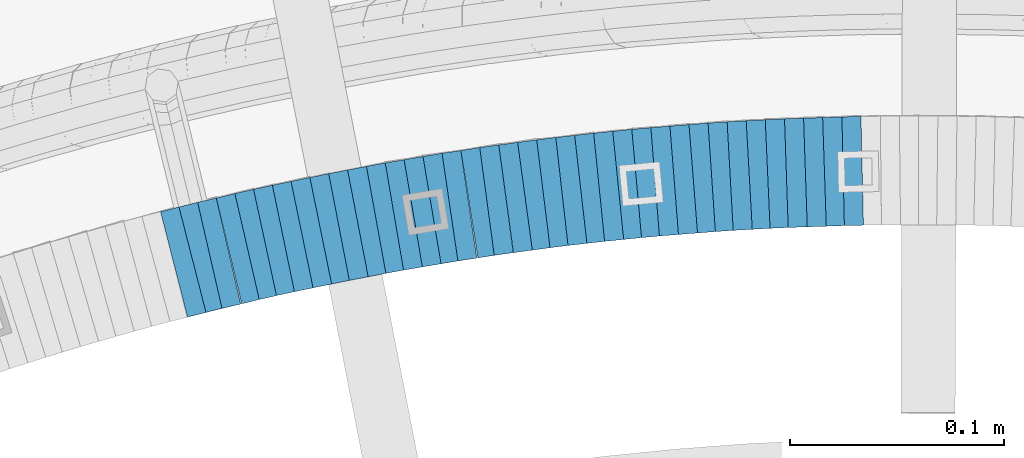
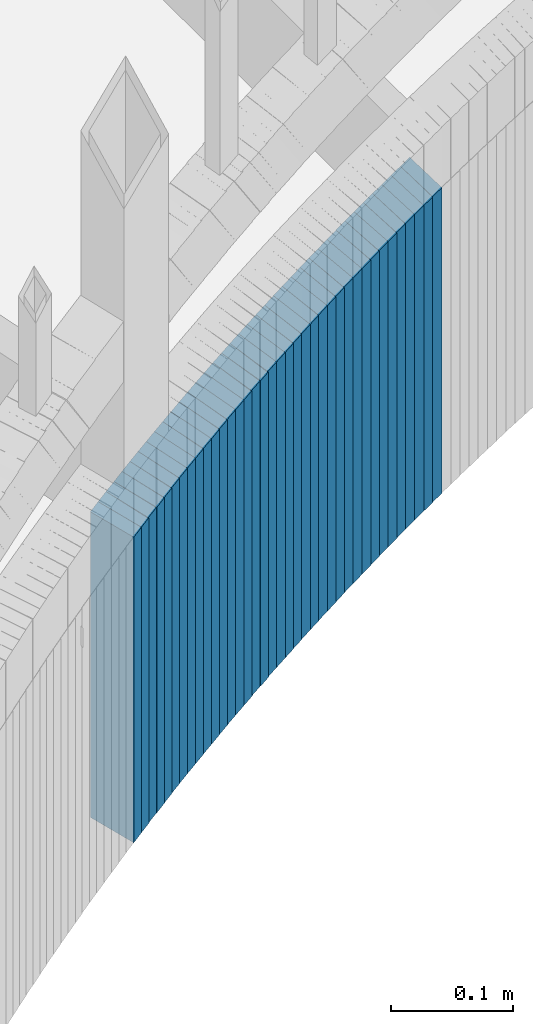
# One storey, part 895 of 975: 37 plates.
"""IFC2X3 building model written with IfcOpenShell, lengths in millimetres."""

from ifc_helpers import new_model, si_unit, frame, origin_with_axes, place, context, subcontext, project, spatial, faceted_brep, material, type_object, element, save


model = new_model("IFC2X3")

# Units and contexts
model_context = context("Model", 3, precision=1e-05, world=origin_with_axes())
body_context = subcontext(model_context, "Body", "Model", "MODEL_VIEW")
ifc_project = project(units=[si_unit("LENGTHUNIT", "METRE", prefix="MILLI"), si_unit("AREAUNIT", "SQUARE_METRE"), si_unit("VOLUMEUNIT", "CUBIC_METRE"), si_unit("MASSUNIT", "GRAM", prefix="KILO"), si_unit("TIMEUNIT", "SECOND"), si_unit("PLANEANGLEUNIT", "RADIAN"), si_unit("SOLIDANGLEUNIT", "STERADIAN"), si_unit("THERMODYNAMICTEMPERATUREUNIT", "DEGREE_CELSIUS"), si_unit("LUMINOUSINTENSITYUNIT", "LUMEN")], contexts=[model_context])

# Site, building, storey
site_placement = place(None, origin_with_axes())
site = spatial("IfcSite", under=ifc_project, at=site_placement, CompositionType="ELEMENT")
building_placement = place(site_placement, origin_with_axes())
building = spatial("IfcBuilding", under=site, at=building_placement, Name="Undefined", CompositionType="ELEMENT")
storey_placement = place(building_placement, origin_with_axes())
storey = spatial("IfcBuildingStorey", under=building, at=storey_placement, Name="Undefined", CompositionType="ELEMENT", Elevation=0.0)

# Plates
ifc_material = material(Name="STEEL/A36")
plate_type = type_object("IfcPlateType", PredefinedType="NOTDEFINED")
plate_1_placement = place(storey_placement, frame((34699.2462043846, 4800.26396393321, 1043.80000000055), z_axis=(0.999747602222632, 0.0224662380050031, 0.0), x_axis=(0.0, 0.0, -1.0)))
element("IfcPlate", 1, at=plate_1_placement, inside=storey, type_object=plate_type, material=ifc_material, Name="WALL", context=body_context, shape_type="Brep", body=[
    faceted_brep([(0.0, -25.3999999999724, -1.81898940354586e-11), (-5.80000019073486, -25.4000000000024, 8.90224647521973), (-5.80000019073486, 25.3999999999996, 8.90224647527066), (0.0, 25.3999999999869, 1.45519152283669e-11), (299.0, -25.4000000000024, 8.90224647521973), (299.0, 25.3999999999996, 8.90224647527066), (304.799987792969, -25.3999999999724, -1.81898940354586e-11), (304.799987792969, 25.3999999999869, 1.45519152283669e-11)], [[[0, 1, 2, 3]], [[1, 4, 5, 2]], [[4, 6, 7, 5]], [[6, 0, 3, 7]], [[5, 7, 3, 2]], [[6, 4, 1, 0]]]),
])
plate_2_placement = place(storey_placement, frame((34690.5217586159, 4799.97165239213, 1038.10000000055), z_axis=(0.999444906986924, 0.0333148299995647, 0.0), x_axis=(0.0, 0.0, -1.0)))
element("IfcPlate", 2, at=plate_2_placement, inside=storey, type_object=plate_type, material=ifc_material, Name="WALL", context=body_context, shape_type="Brep", body=[
    faceted_brep([(0.0, -25.3999999999724, -1.81898940354586e-11), (-5.69999980926514, -25.3999999999724, 9.00000000009459), (-5.69999980926514, 25.3999999999905, 8.99999999997453), (0.0, 25.3999999999869, 1.45519152283669e-11), (299.100006103516, -25.3999999999724, 9.00000000009459), (299.100006103516, 25.3999999999905, 8.99999999997453), (304.799987792969, -25.3999999999724, -1.81898940354586e-11), (304.799987792969, 25.3999999999869, 1.45519152283669e-11)], [[[0, 1, 2, 3]], [[1, 4, 5, 2]], [[4, 6, 7, 5]], [[6, 0, 3, 7]], [[5, 7, 3, 2]], [[6, 4, 1, 0]]]),
])
plate_3_placement = place(storey_placement, frame((34681.6312557283, 4799.6719707406, 1032.30000000056), z_axis=(0.999432373568723, 0.0336887319854623, 0.0), x_axis=(0.0, 0.0, -1.0)))
element("IfcPlate", 3, at=plate_3_placement, inside=storey, type_object=plate_type, material=ifc_material, Name="WALL", context=body_context, shape_type="Brep", body=[
    faceted_brep([(0.0, -25.3999999999724, -1.81898940354586e-11), (-5.80000019073486, -25.399999999976, 8.91066741944087), (-5.80000019073486, 25.4000000000051, 8.91066741945178), (0.0, 25.3999999999869, 1.45519152283669e-11), (299.0, -25.399999999976, 8.91066741944087), (299.0, 25.4000000000051, 8.91066741945178), (304.799987792969, -25.3999999999724, -1.81898940354586e-11), (304.799987792969, 25.3999999999869, 1.45519152283669e-11)], [[[0, 1, 2, 3]], [[1, 4, 5, 2]], [[4, 6, 7, 5]], [[6, 0, 3, 7]], [[5, 7, 3, 2]], [[6, 4, 1, 0]]]),
])
plate_4_placement = place(storey_placement, frame((34672.7312557303, 4799.37197074027, 1026.60000000056), z_axis=(0.999432373568723, 0.0336887319854623, 0.0), x_axis=(0.0, 0.0, -1.0)))
element("IfcPlate", 4, at=plate_4_placement, inside=storey, type_object=plate_type, material=ifc_material, Name="WALL", context=body_context, shape_type="Brep", body=[
    faceted_brep([(0.0, -25.3999999999724, -1.81898940354586e-11), (-5.69999980926514, -25.400000000096, 8.9140338897214), (-5.69999980926514, 25.4000000000524, 8.91403388979779), (0.0, 25.3999999999869, 1.45519152283669e-11), (299.100006103516, -25.400000000096, 8.9140338897214), (299.100006103516, 25.4000000000524, 8.91403388979779), (304.799987792969, -25.3999999999724, -1.81898940354586e-11), (304.799987792969, 25.3999999999869, 1.45519152283669e-11)], [[[0, 1, 2, 3]], [[1, 4, 5, 2]], [[4, 6, 7, 5]], [[6, 0, 3, 7]], [[5, 7, 3, 2]], [[6, 4, 1, 0]]]),
])
plate_5_placement = place(storey_placement, frame((34664.0033375336, 4798.98260234526, 1020.90000000056), z_axis=(0.999013806448466, 0.0444006140199318, 0.0), x_axis=(0.0, 0.0, -1.0)))
element("IfcPlate", 5, at=plate_5_placement, inside=storey, type_object=plate_type, material=ifc_material, Name="WALL", context=body_context, shape_type="Brep", body=[
    faceted_brep([(0.0, -25.3999999999724, -1.81898940354586e-11), (-5.69999980926514, -25.4000000000087, 9.01387786864507), (-5.69999980926514, 25.4000000000124, 9.0138778686669), (0.0, 25.3999999999869, 1.45519152283669e-11), (299.100006103516, -25.4000000000087, 9.01387786864507), (299.100006103516, 25.4000000000124, 9.0138778686669), (304.799987792969, -25.3999999999724, -1.81898940354586e-11), (304.799987792969, 25.3999999999869, 1.45519152283669e-11)], [[[0, 1, 2, 3]], [[1, 4, 5, 2]], [[4, 6, 7, 5]], [[6, 0, 3, 7]], [[5, 7, 3, 2]], [[6, 4, 1, 0]]]),
])
plate_6_placement = place(storey_placement, frame((34655.4002816598, 4798.49754171792, 1015.10000000056), z_axis=(0.99842564215979, 0.0560913280089772, 0.0), x_axis=(0.0, 0.0, -1.0)))
element("IfcPlate", 6, at=plate_6_placement, inside=storey, type_object=plate_type, material=ifc_material, Name="WALL", context=body_context, shape_type="Brep", body=[
    faceted_brep([(0.0, -25.3999999999724, -1.81898940354586e-11), (-5.80000019073486, -25.399999999976, 8.91066741944087), (-5.80000019073486, 25.4000000000051, 8.91066741945178), (0.0, 25.3999999999869, 1.45519152283669e-11), (299.0, -25.399999999976, 8.91066741944087), (299.0, 25.4000000000051, 8.91066741945178), (304.799987792969, -25.3999999999724, -1.81898940354586e-11), (304.799987792969, 25.3999999999869, 1.45519152283669e-11)], [[[0, 1, 2, 3]], [[1, 4, 5, 2]], [[4, 6, 7, 5]], [[6, 0, 3, 7]], [[5, 7, 3, 2]], [[6, 4, 1, 0]]]),
])
plate_7_placement = place(storey_placement, frame((34646.5002816507, 4797.99754171766, 1009.40000000056), z_axis=(0.99842564215979, 0.0560913280089772, 0.0), x_axis=(0.0, 0.0, -1.0)))
element("IfcPlate", 7, at=plate_7_placement, inside=storey, type_object=plate_type, material=ifc_material, Name="WALL", context=body_context, shape_type="Brep", body=[
    faceted_brep([(0.0, -25.3999999999724, -1.81898940354586e-11), (-5.69999980926514, -25.400000000096, 8.9140338897214), (-5.69999980926514, 25.4000000000524, 8.91403388979779), (0.0, 25.3999999999869, 1.45519152283669e-11), (299.100006103516, -25.400000000096, 8.9140338897214), (299.100006103516, 25.4000000000524, 8.91403388979779), (304.799987792969, -25.3999999999724, -1.81898940354586e-11), (304.799987792969, 25.3999999999869, 1.45519152283669e-11)], [[[0, 1, 2, 3]], [[1, 4, 5, 2]], [[4, 6, 7, 5]], [[6, 0, 3, 7]], [[5, 7, 3, 2]], [[6, 4, 1, 0]]]),
])
plate_8_placement = place(storey_placement, frame((34637.8840434402, 4797.41507700762, 1003.70000000056), z_axis=(0.99773527642945, 0.0672630520289523, 0.0), x_axis=(0.0, 0.0, -1.0)))
element("IfcPlate", 8, at=plate_8_placement, inside=storey, type_object=plate_type, material=ifc_material, Name="WALL", context=body_context, shape_type="Brep", body=[
    faceted_brep([(0.0, -25.3999999999724, -1.81898940354586e-11), (-5.69999980926514, -25.3999999999724, 8.91964149478372), (-5.69999980926514, 25.400000000016, 8.9196414947528), (0.0, 25.3999999999869, 1.45519152283669e-11), (299.100006103516, -25.3999999999724, 8.91964149478372), (299.100006103516, 25.400000000016, 8.9196414947528), (304.799987792969, -25.3999999999724, -1.81898940354586e-11), (304.799987792969, 25.3999999999869, 1.45519152283669e-11)], [[[0, 1, 2, 3]], [[1, 4, 5, 2]], [[4, 6, 7, 5]], [[6, 0, 3, 7]], [[5, 7, 3, 2]], [[6, 4, 1, 0]]]),
])
plate_9_placement = place(storey_placement, frame((34629.2671641078, 4796.73575371029, 998.000000000566), z_axis=(0.996921233007399, 0.0784095350005817, 0.0), x_axis=(0.0, 0.0, -1.0)))
element("IfcPlate", 9, at=plate_9_placement, inside=storey, type_object=plate_type, material=ifc_material, Name="WALL", context=body_context, shape_type="Brep", body=[
    faceted_brep([(0.0, -25.3999999999724, -1.81898940354586e-11), (-5.69999980926514, -25.3999999999141, 8.92748546604707), (-5.69999980926514, 25.3999999999505, 8.92748546598159), (0.0, 25.3999999999869, 1.45519152283669e-11), (299.100006103516, -25.3999999999141, 8.92748546604707), (299.100006103516, 25.3999999999505, 8.92748546598159), (304.799987792969, -25.3999999999724, -1.81898940354586e-11), (304.799987792969, 25.3999999999869, 1.45519152283669e-11)], [[[0, 1, 2, 3]], [[1, 4, 5, 2]], [[4, 6, 7, 5]], [[6, 0, 3, 7]], [[5, 7, 3, 2]], [[6, 4, 1, 0]]]),
])
plate_10_placement = place(storey_placement, frame((34620.3671641078, 4796.03575371006, 992.200000000568), z_axis=(0.996921233007399, 0.0784095350005817, 0.0), x_axis=(0.0, 0.0, -1.0)))
element("IfcPlate", 10, at=plate_10_placement, inside=storey, type_object=plate_type, material=ifc_material, Name="WALL", context=body_context, shape_type="Brep", body=[
    faceted_brep([(0.0, -25.3999999999724, -1.81898940354586e-11), (-5.80000019073486, -25.399999999976, 8.9274854660398), (-5.80000019073486, 25.4000000000269, 8.92748546601433), (0.0, 25.3999999999869, 1.45519152283669e-11), (299.0, -25.399999999976, 8.9274854660398), (299.0, 25.4000000000269, 8.92748546601433), (304.799987792969, -25.3999999999724, -1.81898940354586e-11), (304.799987792969, 25.3999999999869, 1.45519152283669e-11)], [[[0, 1, 2, 3]], [[1, 4, 5, 2]], [[4, 6, 7, 5]], [[6, 0, 3, 7]], [[5, 7, 3, 2]], [[6, 4, 1, 0]]]),
])
plate_11_placement = place(storey_placement, frame((34611.4671641079, 4795.33575370981, 986.500000000571), z_axis=(0.996921233007399, 0.0784095350005817, 0.0), x_axis=(0.0, 0.0, -1.0)))
element("IfcPlate", 11, at=plate_11_placement, inside=storey, type_object=plate_type, material=ifc_material, Name="WALL", context=body_context, shape_type="Brep", body=[
    faceted_brep([(0.0, -25.3999999999724, -1.81898940354586e-11), (-5.69999980926514, -25.3999999999141, 8.92748546604707), (-5.69999980926514, 25.3999999999505, 8.92748546598159), (0.0, 25.3999999999869, 1.45519152283669e-11), (299.100006103516, -25.3999999999141, 8.92748546604707), (299.100006103516, 25.3999999999505, 8.92748546598159), (304.799987792969, -25.3999999999724, -1.81898940354586e-11), (304.799987792969, 25.3999999999869, 1.45519152283669e-11)], [[[0, 1, 2, 3]], [[1, 4, 5, 2]], [[4, 6, 7, 5]], [[6, 0, 3, 7]], [[5, 7, 3, 2]], [[6, 4, 1, 0]]]),
])
plate_12_placement = place(storey_placement, frame((34602.8495398424, 4794.55954867236, 980.800000000572), z_axis=(0.995984423457655, 0.0895266900411373, 0.0), x_axis=(0.0, 0.0, -1.0)))
element("IfcPlate", 12, at=plate_12_placement, inside=storey, type_object=plate_type, material=ifc_material, Name="WALL", context=body_context, shape_type="Brep", body=[
    faceted_brep([(0.0, -25.3999999999724, -1.81898940354586e-11), (-5.69999980926514, -25.4000000000415, 8.93756103511259), (-5.69999980926514, 25.4000000000815, 8.93756103522537), (0.0, 25.3999999999869, 1.45519152283669e-11), (299.100006103516, -25.4000000000415, 8.93756103511259), (299.100006103516, 25.4000000000815, 8.93756103522537), (304.799987792969, -25.3999999999724, -1.81898940354586e-11), (304.799987792969, 25.3999999999869, 1.45519152283669e-11)], [[[0, 1, 2, 3]], [[1, 4, 5, 2]], [[4, 6, 7, 5]], [[6, 0, 3, 7]], [[5, 7, 3, 2]], [[6, 4, 1, 0]]]),
])
plate_13_placement = place(storey_placement, frame((34594.2310681834, 4793.68643536917, 975.000000000569), z_axis=(0.994925892068904, 0.100610483006968, 0.0), x_axis=(0.0, 0.0, -1.0)))
element("IfcPlate", 13, at=plate_13_placement, inside=storey, type_object=plate_type, material=ifc_material, Name="WALL", context=body_context, shape_type="Brep", body=[
    faceted_brep([(0.0, -25.3999999999724, -1.81898940354586e-11), (-5.80000019073486, -25.4000000000742, 8.94706630702785), (-5.80000019073486, 25.4000000000306, 8.9470663070897), (0.0, 25.3999999999869, 1.45519152283669e-11), (299.0, -25.4000000000742, 8.94706630702785), (299.0, 25.4000000000306, 8.9470663070897), (304.799987792969, -25.3999999999724, -1.81898940354586e-11), (304.799987792969, 25.3999999999869, 1.45519152283669e-11)], [[[0, 1, 2, 3]], [[1, 4, 5, 2]], [[4, 6, 7, 5]], [[6, 0, 3, 7]], [[5, 7, 3, 2]], [[6, 4, 1, 0]]]),
])
plate_14_placement = place(storey_placement, frame((34585.3310681832, 4792.78643536868, 969.300000000569), z_axis=(0.994925892068904, 0.100610483006968, 0.0), x_axis=(0.0, 0.0, -1.0)))
element("IfcPlate", 14, at=plate_14_placement, inside=storey, type_object=plate_type, material=ifc_material, Name="WALL", context=body_context, shape_type="Brep", body=[
    faceted_brep([(0.0, -25.3999999999724, -1.81898940354586e-11), (-5.69999980926514, -25.4000000000451, 8.94986057279493), (-5.69999980926514, 25.3999999999942, 8.94986057280948), (0.0, 25.3999999999869, 1.45519152283669e-11), (299.100006103516, -25.4000000000451, 8.94986057279493), (299.100006103516, 25.3999999999942, 8.94986057280948), (304.799987792969, -25.3999999999724, -1.81898940354586e-11), (304.799987792969, 25.3999999999869, 1.45519152283669e-11)], [[[0, 1, 2, 3]], [[1, 4, 5, 2]], [[4, 6, 7, 5]], [[6, 0, 3, 7]], [[5, 7, 3, 2]], [[6, 4, 1, 0]]]),
])
plate_15_placement = place(storey_placement, frame((34576.7116483129, 4791.81638399891, 963.600000000574), z_axis=(0.993746812135698, 0.111656945015246, 0.0), x_axis=(0.0, 0.0, -1.0)))
element("IfcPlate", 15, at=plate_15_placement, inside=storey, type_object=plate_type, material=ifc_material, Name="WALL", context=body_context, shape_type="Brep", body=[
    faceted_brep([(0.0, -25.3999999999724, -1.81898940354586e-11), (-5.69999980926514, -25.4000000000087, 8.9643735885511), (-5.69999980926514, 25.4000000000669, 8.96437358860567), (0.0, 25.3999999999869, 1.45519152283669e-11), (299.100006103516, -25.4000000000087, 8.9643735885511), (299.100006103516, 25.4000000000669, 8.96437358860567), (304.799987792969, -25.3999999999724, -1.81898940354586e-11), (304.799987792969, 25.3999999999869, 1.45519152283669e-11)], [[[0, 1, 2, 3]], [[1, 4, 5, 2]], [[4, 6, 7, 5]], [[6, 0, 3, 7]], [[5, 7, 3, 2]], [[6, 4, 1, 0]]]),
])
plate_16_placement = place(storey_placement, frame((34567.9434679781, 4790.81997955472, 957.800000000571), z_axis=(0.993605254797368, 0.112909687976973, 0.0), x_axis=(0.0, 0.0, -1.0)))
element("IfcPlate", 16, at=plate_16_placement, inside=storey, type_object=plate_type, material=ifc_material, Name="WALL", context=body_context, shape_type="Brep", body=[
    faceted_brep([(0.0, -25.3999999999724, -1.81898940354586e-11), (-5.80000019073486, -25.3999999999905, 8.8617153167761), (-5.80000019073486, 25.4000000000524, 8.86171531681975), (0.0, 25.3999999999869, 1.45519152283669e-11), (299.0, -25.3999999999905, 8.8617153167761), (299.0, 25.4000000000524, 8.86171531681975), (304.799987792969, -25.3999999999724, -1.81898940354586e-11), (304.799987792969, 25.3999999999869, 1.45519152283669e-11)], [[[0, 1, 2, 3]], [[1, 4, 5, 2]], [[4, 6, 7, 5]], [[6, 0, 3, 7]], [[5, 7, 3, 2]], [[6, 4, 1, 0]]]),
])
plate_17_placement = place(storey_placement, frame((34559.2911810765, 4789.74936155629, 952.100000000571), z_axis=(0.99244848307505, 0.122662172009276, 0.0), x_axis=(0.0, 0.0, -1.0)))
element("IfcPlate", 17, at=plate_17_placement, inside=storey, type_object=plate_type, material=ifc_material, Name="WALL", context=body_context, shape_type="Brep", body=[
    faceted_brep([(0.0, -25.3999999999724, -1.81898940354586e-11), (-5.69999980926514, -25.4000000000669, 8.96939277644015), (-5.69999980926514, 25.4000000000524, 8.96939277652928), (0.0, 25.3999999999869, 1.45519152283669e-11), (299.100006103516, -25.4000000000669, 8.96939277644015), (299.100006103516, 25.4000000000524, 8.96939277652928), (304.799987792969, -25.3999999999724, -1.81898940354586e-11), (304.799987792969, 25.3999999999869, 1.45519152283669e-11)], [[[0, 1, 2, 3]], [[1, 4, 5, 2]], [[4, 6, 7, 5]], [[6, 0, 3, 7]], [[5, 7, 3, 2]], [[6, 4, 1, 0]]]),
])
plate_18_placement = place(storey_placement, frame((34550.6695692369, 4788.58533194364, 946.400000000574), z_axis=(0.991032326071816, 0.133622336009684, 0.0), x_axis=(0.0, 0.0, -1.0)))
element("IfcPlate", 18, at=plate_18_placement, inside=storey, type_object=plate_type, material=ifc_material, Name="WALL", context=body_context, shape_type="Brep", body=[
    faceted_brep([(0.0, -25.3999999999724, -1.81898940354586e-11), (-5.69999980926514, -25.3999999999833, 8.98053455353147), (-5.69999980926514, 25.3999999999396, 8.98053455348781), (0.0, 25.3999999999869, 1.45519152283669e-11), (299.100006103516, -25.3999999999833, 8.98053455353147), (299.100006103516, 25.3999999999396, 8.98053455348781), (304.799987792969, -25.3999999999724, -1.81898940354586e-11), (304.799987792969, 25.3999999999869, 1.45519152283669e-11)], [[[0, 1, 2, 3]], [[1, 4, 5, 2]], [[4, 6, 7, 5]], [[6, 0, 3, 7]], [[5, 7, 3, 2]], [[6, 4, 1, 0]]]),
])
plate_19_placement = place(storey_placement, frame((34541.907437305, 4787.39046675779, 940.700000000578), z_axis=(0.990830168007788, 0.135113205001062, 0.0), x_axis=(0.0, 0.0, -1.0)))
element("IfcPlate", 19, at=plate_19_placement, inside=storey, type_object=plate_type, material=ifc_material, Name="WALL", context=body_context, shape_type="Brep", body=[
    faceted_brep([(0.0, -25.3999999999724, -1.81898940354586e-11), (-5.69999980926514, -25.4000000000669, 8.8814411163039), (-5.69999980926514, 25.400000000096, 8.88144111637848), (0.0, 25.3999999999869, 1.45519152283669e-11), (299.100006103516, -25.4000000000669, 8.8814411163039), (299.100006103516, 25.400000000096, 8.88144111637848), (304.799987792969, -25.3999999999724, -1.81898940354586e-11), (304.799987792969, 25.3999999999869, 1.45519152283669e-11)], [[[0, 1, 2, 3]], [[1, 4, 5, 2]], [[4, 6, 7, 5]], [[6, 0, 3, 7]], [[5, 7, 3, 2]], [[6, 4, 1, 0]]]),
])
plate_20_placement = place(storey_placement, frame((34532.9695692275, 4786.18533194244, 934.900000000581), z_axis=(0.991032326071816, 0.133622336009684, 0.0), x_axis=(0.0, 0.0, -1.0)))
element("IfcPlate", 20, at=plate_20_placement, inside=storey, type_object=plate_type, material=ifc_material, Name="WALL", context=body_context, shape_type="Brep", body=[
    faceted_brep([(0.0, -25.3999999999724, -1.81898940354586e-11), (-5.80000019073486, -25.3999999999542, 8.98276138308574), (-5.80000019073486, 25.3999999999469, 8.98276138302026), (0.0, 25.3999999999869, 1.45519152283669e-11), (299.0, -25.3999999999542, 8.98276138308574), (299.0, 25.3999999999469, 8.98276138302026), (304.799987792969, -25.3999999999724, -1.81898940354586e-11), (304.799987792969, 25.3999999999869, 1.45519152283669e-11)], [[[0, 1, 2, 3]], [[1, 4, 5, 2]], [[4, 6, 7, 5]], [[6, 0, 3, 7]], [[5, 7, 3, 2]], [[6, 4, 1, 0]]]),
])
plate_21_placement = place(storey_placement, frame((34524.766284137, 4784.87301324441, 929.200000000585), z_axis=(0.987580306285744, 0.157115049045458, 0.0), x_axis=(0.0, 0.0, -1.0)))
element("IfcPlate", 21, at=plate_21_placement, inside=storey, type_object=plate_type, material=ifc_material, Name="WALL", context=body_context, shape_type="Brep", body=[
    faceted_brep([(0.0, -25.3999999999724, -1.81898940354586e-11), (-5.69999980926514, -25.400000000096, 8.9140338897214), (-5.69999980926514, 25.4000000000524, 8.91403388979779), (0.0, 25.3999999999869, 1.45519152283669e-11), (299.100006103516, -25.400000000096, 8.9140338897214), (299.100006103516, 25.4000000000524, 8.91403388979779), (304.799987792969, -25.3999999999724, -1.81898940354586e-11), (304.799987792969, 25.3999999999869, 1.45519152283669e-11)], [[[0, 1, 2, 3]], [[1, 4, 5, 2]], [[4, 6, 7, 5]], [[6, 0, 3, 7]], [[5, 7, 3, 2]], [[6, 4, 1, 0]]]),
])
plate_22_placement = place(storey_placement, frame((34515.6875492319, 4783.53025412516, 923.500000000585), z_axis=(0.989263736178206, 0.146141234026325, 0.0), x_axis=(0.0, 0.0, -1.0)))
element("IfcPlate", 22, at=plate_22_placement, inside=storey, type_object=plate_type, material=ifc_material, Name="WALL", context=body_context, shape_type="Brep", body=[
    faceted_brep([(0.0, -25.3999999999724, -1.81898940354586e-11), (-5.69999980926514, -25.3999999999724, 8.90224647524519), (-5.69999980926514, 25.3999999999542, 8.90224647519426), (0.0, 25.3999999999869, 1.45519152283669e-11), (299.100006103516, -25.3999999999724, 8.90224647524519), (299.100006103516, 25.3999999999542, 8.90224647519426), (304.799987792969, -25.3999999999724, -1.81898940354586e-11), (304.799987792969, 25.3999999999869, 1.45519152283669e-11)], [[[0, 1, 2, 3]], [[1, 4, 5, 2]], [[4, 6, 7, 5]], [[6, 0, 3, 7]], [[5, 7, 3, 2]], [[6, 4, 1, 0]]]),
])
plate_23_placement = place(storey_placement, frame((34507.2969256076, 4782.11079498323, 917.700000000591), z_axis=(0.986092836244413, 0.166195422041193, 0.0), x_axis=(0.0, 0.0, -1.0)))
element("IfcPlate", 23, at=plate_23_placement, inside=storey, type_object=plate_type, material=ifc_material, Name="WALL", context=body_context, shape_type="Brep", body=[
    faceted_brep([(0.0, -25.3999999999724, -1.81898940354586e-11), (-5.80000019073486, -25.3999999999936, 9.02551937102544), (-5.80000019073486, 25.3999999999775, 9.0255193710982), (0.0, 25.3999999999869, 1.45519152283669e-11), (299.0, -25.3999999999936, 9.02551937102544), (299.0, 25.3999999999775, 9.0255193710982), (304.799987792969, -25.3999999999724, -1.81898940354586e-11), (304.799987792969, 25.3999999999869, 1.45519152283669e-11)], [[[0, 1, 2, 3]], [[1, 4, 5, 2]], [[4, 6, 7, 5]], [[6, 0, 3, 7]], [[5, 7, 3, 2]], [[6, 4, 1, 0]]]),
])
plate_24_placement = place(storey_placement, frame((34498.5435486239, 4780.61869743495, 912.00000000059), z_axis=(0.985781716087097, 0.168030974014847, 0.0), x_axis=(0.0, 0.0, -1.0)))
element("IfcPlate", 24, at=plate_24_placement, inside=storey, type_object=plate_type, material=ifc_material, Name="WALL", context=body_context, shape_type="Brep", body=[
    faceted_brep([(0.0, -25.3999999999724, -1.81898940354586e-11), (-5.69999980926514, -25.3999999999141, 8.92748546604707), (-5.69999980926514, 25.3999999999505, 8.92748546598159), (0.0, 25.3999999999869, 1.45519152283669e-11), (299.100006103516, -25.3999999999141, 8.92748546604707), (299.100006103516, 25.3999999999505, 8.92748546598159), (304.799987792969, -25.3999999999724, -1.81898940354586e-11), (304.799987792969, 25.3999999999869, 1.45519152283669e-11)], [[[0, 1, 2, 3]], [[1, 4, 5, 2]], [[4, 6, 7, 5]], [[6, 0, 3, 7]], [[5, 7, 3, 2]], [[6, 4, 1, 0]]]),
])
plate_25_placement = place(storey_placement, frame((34489.74354862, 4779.11869743445, 906.20000000059), z_axis=(0.985781716087097, 0.168030974014847, 0.0), x_axis=(0.0, 0.0, -1.0)))
element("IfcPlate", 25, at=plate_25_placement, inside=storey, type_object=plate_type, material=ifc_material, Name="WALL", context=body_context, shape_type="Brep", body=[
    faceted_brep([(0.0, -25.3999999999724, -1.81898940354586e-11), (-5.80000019073486, -25.399999999976, 8.9274854660398), (-5.80000019073486, 25.4000000000269, 8.92748546601433), (0.0, 25.3999999999869, 1.45519152283669e-11), (299.0, -25.399999999976, 8.9274854660398), (299.0, 25.4000000000269, 8.92748546601433), (304.799987792969, -25.3999999999724, -1.81898940354586e-11), (304.799987792969, 25.3999999999869, 1.45519152283669e-11)], [[[0, 1, 2, 3]], [[1, 4, 5, 2]], [[4, 6, 7, 5]], [[6, 0, 3, 7]], [[5, 7, 3, 2]], [[6, 4, 1, 0]]]),
])
plate_26_placement = place(storey_placement, frame((34481.2192520124, 4777.5672573058, 900.500000000593), z_axis=(0.983869910131907, 0.178885438023984, 0.0), x_axis=(0.0, 0.0, -1.0)))
element("IfcPlate", 26, at=plate_26_placement, inside=storey, type_object=plate_type, material=ifc_material, Name="WALL", context=body_context, shape_type="Brep", body=[
    faceted_brep([(0.0, -25.3999999999724, -1.81898940354586e-11), (-5.69999980926514, -25.4000000000415, 8.93756103511259), (-5.69999980926514, 25.4000000000815, 8.93756103522537), (0.0, 25.3999999999869, 1.45519152283669e-11), (299.100006103516, -25.4000000000415, 8.93756103511259), (299.100006103516, 25.4000000000815, 8.93756103522537), (304.799987792969, -25.3999999999724, -1.81898940354586e-11), (304.799987792969, 25.3999999999869, 1.45519152283669e-11)], [[[0, 1, 2, 3]], [[1, 4, 5, 2]], [[4, 6, 7, 5]], [[6, 0, 3, 7]], [[5, 7, 3, 2]], [[6, 4, 1, 0]]]),
])
plate_27_placement = place(storey_placement, frame((34472.6933062735, 4775.91864087775, 894.700000000596), z_axis=(0.98184693485788, 0.189674975972545, 0.0), x_axis=(0.0, 0.0, -1.0)))
element("IfcPlate", 27, at=plate_27_placement, inside=storey, type_object=plate_type, material=ifc_material, Name="WALL", context=body_context, shape_type="Brep", body=[
    faceted_brep([(0.0, -25.3999999999724, -1.81898940354586e-11), (-5.80000019073486, -25.3999999999396, 8.9627008438656), (-5.80000019073486, 25.3999999999178, 8.96270084374191), (0.0, 25.3999999999869, 1.45519152283669e-11), (299.0, -25.3999999999396, 8.9627008438656), (299.0, 25.3999999999178, 8.96270084374191), (304.799987792969, -25.3999999999724, -1.81898940354586e-11), (304.799987792969, 25.3999999999869, 1.45519152283669e-11)], [[[0, 1, 2, 3]], [[1, 4, 5, 2]], [[4, 6, 7, 5]], [[6, 0, 3, 7]], [[5, 7, 3, 2]], [[6, 4, 1, 0]]]),
])
plate_28_placement = place(storey_placement, frame((34463.8933062707, 4774.21864087764, 889.000000000598), z_axis=(0.98184693485788, 0.189674975972545, 0.0), x_axis=(0.0, 0.0, -1.0)))
element("IfcPlate", 28, at=plate_28_placement, inside=storey, type_object=plate_type, material=ifc_material, Name="WALL", context=body_context, shape_type="Brep", body=[
    faceted_brep([(0.0, -25.3999999999724, -1.81898940354586e-11), (-5.69999980926514, -25.4000000000087, 8.9643735885511), (-5.69999980926514, 25.4000000000669, 8.96437358860567), (0.0, 25.3999999999869, 1.45519152283669e-11), (299.100006103516, -25.4000000000087, 8.9643735885511), (299.100006103516, 25.4000000000669, 8.96437358860567), (304.799987792969, -25.3999999999724, -1.81898940354586e-11), (304.799987792969, 25.3999999999869, 1.45519152283669e-11)], [[[0, 1, 2, 3]], [[1, 4, 5, 2]], [[4, 6, 7, 5]], [[6, 0, 3, 7]], [[5, 7, 3, 2]], [[6, 4, 1, 0]]]),
])
plate_29_placement = place(storey_placement, frame((34455.3656262803, 4772.47279374238, 883.300000000604), z_axis=(0.979714932300414, 0.200396236061448, 0.0), x_axis=(0.0, 0.0, -1.0)))
element("IfcPlate", 29, at=plate_29_placement, inside=storey, type_object=plate_type, material=ifc_material, Name="WALL", context=body_context, shape_type="Brep", body=[
    faceted_brep([(0.0, -25.3999999999724, -1.81898940354586e-11), (-5.69999980926514, -25.3999999999833, 8.98053455353147), (-5.69999980926514, 25.3999999999396, 8.98053455348781), (0.0, 25.3999999999869, 1.45519152283669e-11), (299.100006103516, -25.3999999999833, 8.98053455353147), (299.100006103516, 25.3999999999396, 8.98053455348781), (304.799987792969, -25.3999999999724, -1.81898940354586e-11), (304.799987792969, 25.3999999999869, 1.45519152283669e-11)], [[[0, 1, 2, 3]], [[1, 4, 5, 2]], [[4, 6, 7, 5]], [[6, 0, 3, 7]], [[5, 7, 3, 2]], [[6, 4, 1, 0]]]),
])
plate_30_placement = place(storey_placement, frame((34446.5656262836, 4770.67279374238, 877.500000000609), z_axis=(0.979714932300414, 0.200396236061448, 0.0), x_axis=(0.0, 0.0, -1.0)))
element("IfcPlate", 30, at=plate_30_placement, inside=storey, type_object=plate_type, material=ifc_material, Name="WALL", context=body_context, shape_type="Brep", body=[
    faceted_brep([(0.0, -25.3999999999724, -1.81898940354586e-11), (-5.80000019073486, -25.3999999999542, 8.98276138308574), (-5.80000019073486, 25.3999999999469, 8.98276138302026), (0.0, 25.3999999999869, 1.45519152283669e-11), (299.0, -25.3999999999542, 8.98276138308574), (299.0, 25.3999999999469, 8.98276138302026), (304.799987792969, -25.3999999999724, -1.81898940354586e-11), (304.799987792969, 25.3999999999869, 1.45519152283669e-11)], [[[0, 1, 2, 3]], [[1, 4, 5, 2]], [[4, 6, 7, 5]], [[6, 0, 3, 7]], [[5, 7, 3, 2]], [[6, 4, 1, 0]]]),
])
plate_31_placement = place(storey_placement, frame((34437.9217442245, 4768.88433836663, 871.800000000609), z_axis=(0.979260419534469, 0.202605603903684, 0.0), x_axis=(0.0, 0.0, -1.0)))
element("IfcPlate", 31, at=plate_31_placement, inside=storey, type_object=plate_type, material=ifc_material, Name="WALL", context=body_context, shape_type="Brep", body=[
    faceted_brep([(0.0, -25.3999999999724, -1.81898940354586e-11), (-5.69999980926514, -25.4000000000669, 8.8814411163039), (-5.69999980926514, 25.400000000096, 8.88144111637848), (0.0, 25.3999999999869, 1.45519152283669e-11), (299.100006103516, -25.4000000000669, 8.8814411163039), (299.100006103516, 25.400000000096, 8.88144111637848), (304.799987792969, -25.3999999999724, -1.81898940354586e-11), (304.799987792969, 25.3999999999869, 1.45519152283669e-11)], [[[0, 1, 2, 3]], [[1, 4, 5, 2]], [[4, 6, 7, 5]], [[6, 0, 3, 7]], [[5, 7, 3, 2]], [[6, 4, 1, 0]]]),
])
plate_32_placement = place(storey_placement, frame((34429.33612988, 4767.02965921789, 866.000000000609), z_axis=(0.97747613404784, 0.21104598401033, 0.0), x_axis=(0.0, 0.0, -1.0)))
element("IfcPlate", 32, at=plate_32_placement, inside=storey, type_object=plate_type, material=ifc_material, Name="WALL", context=body_context, shape_type="Brep", body=[
    faceted_brep([(0.0, -25.3999999999724, -1.81898940354586e-11), (-5.80000019073486, -25.3999999999578, 8.99610996247975), (-5.80000019073486, 25.3999999999796, 8.99610996245065), (0.0, 25.3999999999869, 1.45519152283669e-11), (299.0, -25.3999999999578, 8.99610996247975), (299.0, 25.3999999999796, 8.99610996245065), (304.799987792969, -25.3999999999724, -1.81898940354586e-11), (304.799987792969, 25.3999999999869, 1.45519152283669e-11)], [[[0, 1, 2, 3]], [[1, 4, 5, 2]], [[4, 6, 7, 5]], [[6, 0, 3, 7]], [[5, 7, 3, 2]], [[6, 4, 1, 0]]]),
])
plate_33_placement = place(storey_placement, frame((34420.9662108776, 4765.10322988477, 860.300000000615), z_axis=(0.974579651097025, 0.224041299022305, 0.0), x_axis=(0.0, 0.0, -1.0)))
element("IfcPlate", 33, at=plate_33_placement, inside=storey, type_object=plate_type, material=ifc_material, Name="WALL", context=body_context, shape_type="Brep", body=[
    faceted_brep([(0.0, -25.3999999999724, -1.81898940354586e-11), (-5.69999980926514, -25.3999999999141, 8.92748546604707), (-5.69999980926514, 25.3999999999505, 8.92748546598159), (0.0, 25.3999999999869, 1.45519152283669e-11), (299.100006103516, -25.3999999999141, 8.92748546604707), (299.100006103516, 25.3999999999505, 8.92748546598159), (304.799987792969, -25.3999999999724, -1.81898940354586e-11), (304.799987792969, 25.3999999999869, 1.45519152283669e-11)], [[[0, 1, 2, 3]], [[1, 4, 5, 2]], [[4, 6, 7, 5]], [[6, 0, 3, 7]], [[5, 7, 3, 2]], [[6, 4, 1, 0]]]),
])
plate_34_placement = place(storey_placement, frame((34412.5354314192, 4763.06666492357, 854.500000000617), z_axis=(0.972082208620478, 0.234640532908391, 0.0), x_axis=(0.0, 0.0, -1.0)))
element("IfcPlate", 34, at=plate_34_placement, inside=storey, type_object=plate_type, material=ifc_material, Name="WALL", context=body_context, shape_type="Brep", body=[
    faceted_brep([(0.0, -25.3999999999724, -1.81898940354586e-11), (-5.80000019073486, -25.4000000000742, 8.94706630702785), (-5.80000019073486, 25.4000000000306, 8.9470663070897), (0.0, 25.3999999999869, 1.45519152283669e-11), (299.0, -25.4000000000742, 8.94706630702785), (299.0, 25.4000000000306, 8.9470663070897), (304.799987792969, -25.3999999999724, -1.81898940354586e-11), (304.799987792969, 25.3999999999869, 1.45519152283669e-11)], [[[0, 1, 2, 3]], [[1, 4, 5, 2]], [[4, 6, 7, 5]], [[6, 0, 3, 7]], [[5, 7, 3, 2]], [[6, 4, 1, 0]]]),
])
plate_35_placement = place(storey_placement, frame((34403.5662108749, 4761.0032298846, 848.800000000623), z_axis=(0.974579651097025, 0.224041299022305, 0.0), x_axis=(0.0, 0.0, -1.0)))
element("IfcPlate", 35, at=plate_35_placement, inside=storey, type_object=plate_type, material=ifc_material, Name="WALL", context=body_context, shape_type="Brep", body=[
    faceted_brep([(0.0, -25.3999999999724, -1.81898940354586e-11), (-5.69999980926514, -25.3999999999141, 8.92748546604707), (-5.69999980926514, 25.3999999999505, 8.92748546598159), (0.0, 25.3999999999869, 1.45519152283669e-11), (299.100006103516, -25.3999999999141, 8.92748546604707), (299.100006103516, 25.3999999999505, 8.92748546598159), (304.799987792969, -25.3999999999724, -1.81898940354586e-11), (304.799987792969, 25.3999999999869, 1.45519152283669e-11)], [[[0, 1, 2, 3]], [[1, 4, 5, 2]], [[4, 6, 7, 5]], [[6, 0, 3, 7]], [[5, 7, 3, 2]], [[6, 4, 1, 0]]]),
])
plate_36_placement = place(storey_placement, frame((34395.4025429704, 4758.93267319592, 843.100000000627), z_axis=(0.969483457682417, 0.245156736150867, -1.44854766404024e-10), x_axis=(0.0, 0.0, -1.0)))
element("IfcPlate", 36, at=plate_36_placement, inside=storey, type_object=plate_type, material=ifc_material, Name="WALL", context=body_context, shape_type="Brep", body=[
    faceted_brep([(0.0, -25.3999999999724, -1.81898940354586e-11), (-5.69999980926514, -25.4000000000669, 8.96939277644015), (-5.69999980926514, 25.4000000000524, 8.96939277652928), (0.0, 25.3999999999869, 1.45519152283669e-11), (299.100006103516, -25.4000000000669, 8.96939277644015), (299.100006103516, 25.4000000000524, 8.96939277652928), (304.799987792969, -25.3999999999724, -1.81898940354586e-11), (304.799987792969, 25.3999999999869, 1.45519152283669e-11)], [[[0, 1, 2, 3]], [[1, 4, 5, 2]], [[4, 6, 7, 5]], [[6, 0, 3, 7]], [[5, 7, 3, 2]], [[6, 4, 1, 0]]]),
])
plate_37_placement = place(storey_placement, frame((34386.8705264312, 4756.74996432921, 837.300000000628), z_axis=(0.968802704444063, 0.247833250113597, 0.0), x_axis=(0.0, 0.0, -1.0)))
element("IfcPlate", 37, at=plate_37_placement, inside=storey, type_object=plate_type, material=ifc_material, Name="WALL", context=body_context, shape_type="Brep", body=[
    faceted_brep([(0.0, -25.3999999999724, -1.81898940354586e-11), (-5.80000019073486, -25.4000000000015, 8.88144111634028), (-5.80000019073486, 25.4000000000269, 8.88144111639849), (0.0, 25.3999999999869, 1.45519152283669e-11), (299.0, -25.4000000000015, 8.88144111634028), (299.0, 25.4000000000269, 8.88144111639849), (304.799987792969, -25.3999999999724, -1.81898940354586e-11), (304.799987792969, 25.3999999999869, 1.45519152283669e-11)], [[[0, 1, 2, 3]], [[1, 4, 5, 2]], [[4, 6, 7, 5]], [[6, 0, 3, 7]], [[5, 7, 3, 2]], [[6, 4, 1, 0]]]),
])

save(model, "model.ifc")
